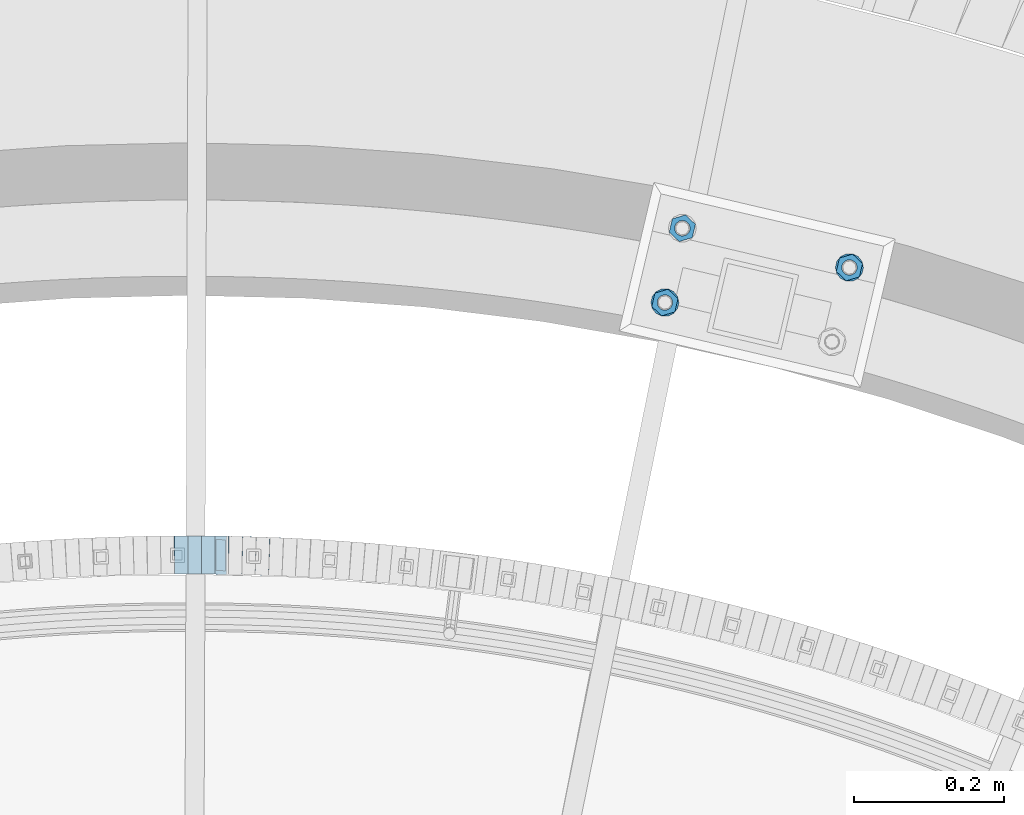
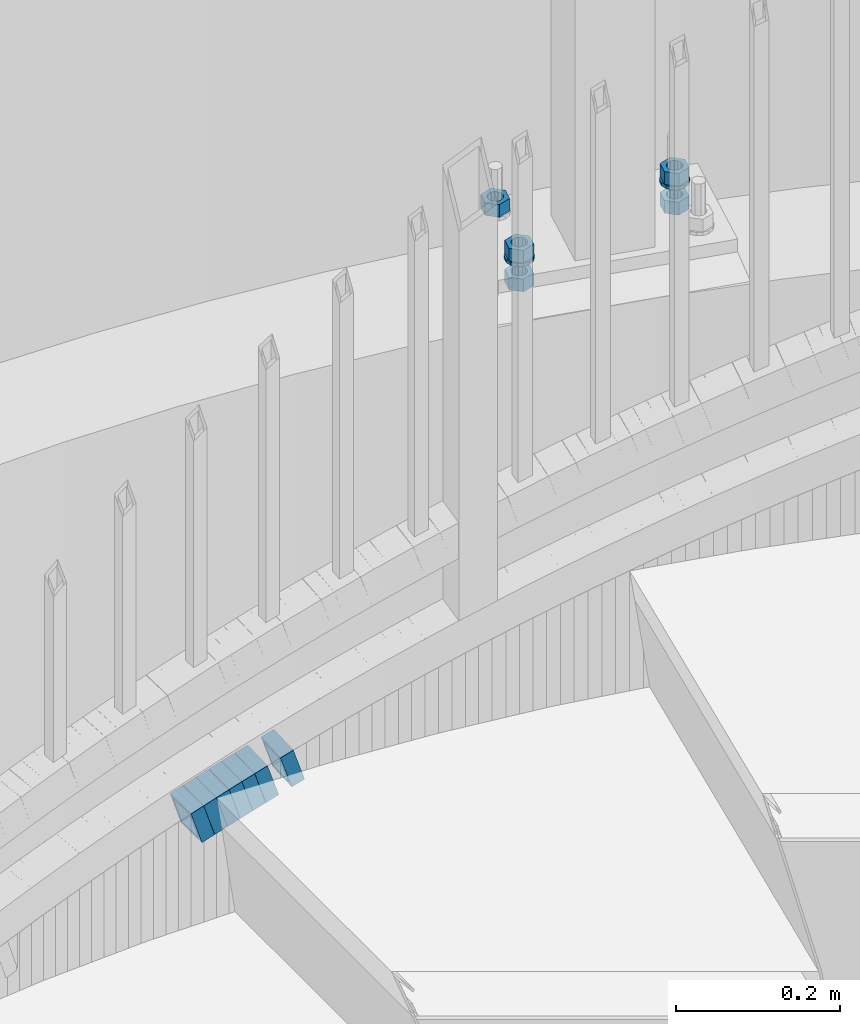
# One storey, part 821 of 975: 14 beams.
"""IFC2X3 building model written with IfcOpenShell, lengths in millimetres."""

from ifc_helpers import new_model, si_unit, frame, origin_with_axes, place, context, subcontext, project, spatial, faceted_brep, material, type_object, element, save


model = new_model("IFC2X3")

# Units and contexts
model_context = context("Model", 3, precision=1e-05, world=origin_with_axes())
body_context = subcontext(model_context, "Body", "Model", "MODEL_VIEW")
ifc_project = project(units=[si_unit("LENGTHUNIT", "METRE", prefix="MILLI"), si_unit("AREAUNIT", "SQUARE_METRE"), si_unit("VOLUMEUNIT", "CUBIC_METRE"), si_unit("MASSUNIT", "GRAM", prefix="KILO"), si_unit("TIMEUNIT", "SECOND"), si_unit("PLANEANGLEUNIT", "RADIAN"), si_unit("SOLIDANGLEUNIT", "STERADIAN"), si_unit("THERMODYNAMICTEMPERATUREUNIT", "DEGREE_CELSIUS"), si_unit("LUMINOUSINTENSITYUNIT", "LUMEN")], contexts=[model_context])

# Site, building, storey
site_placement = place(None, origin_with_axes())
site = spatial("IfcSite", under=ifc_project, at=site_placement, CompositionType="ELEMENT")
building_placement = place(site_placement, origin_with_axes())
building = spatial("IfcBuilding", under=site, at=building_placement, Name="Undefined", CompositionType="ELEMENT")
storey_placement = place(building_placement, origin_with_axes())
storey = spatial("IfcBuildingStorey", under=building, at=storey_placement, Name="Undefined", CompositionType="ELEMENT", Elevation=0.0)

# Beams
ifc_material_1 = material()
beam_type_1 = type_object("IfcBeamType", Name="HSS2X2X.188_TUBES", PredefinedType="NOTDEFINED")
beam_1_placement = place(storey_placement, frame((34814.5687142404, 6273.07633758359, 1065.63622706444), z_axis=(-0.0223407912578623, -0.999750413376245, -8.07874585007085e-11), x_axis=(-0.951092204255929, 0.0212534570057345, -0.308175128082886)))
element("IfcBeam", 1, at=beam_1_placement, inside=storey, type_object=beam_type_1, material=ifc_material_1, Name="WALL", ObjectType="HSS2X2X.188_TUBES", context=body_context, shape_type="Brep", body=[
    faceted_brep([(0.0, 20.6374999999753, -20.6375000000298), (0.0, -20.6375000000153, -20.6375000000153), (18.8225928075335, -20.6374999999935, -20.6375000000298), (18.8225928075699, 20.6374999999898, -20.6374999999825), (0.0, -20.6374999999825, 20.6375000000335), (18.8225928075772, -20.637500000008, 20.6375000000226), (0.0, 20.6375000000116, 20.6375000000189), (18.8225928076135, 20.6374999999753, 20.6375000000698), (0.0, 25.3999999999724, -25.4000000000342), (0.0, 25.400000000016, 25.4000000000196), (18.8225928076281, 25.3999999999705, 25.4000000000815), (18.8225928075663, 25.3999999999905, -25.3999999999796), (0.0, -25.399999999976, 25.4000000000378), (18.8225928075808, -25.4000000000087, 25.4000000000233), (0.0, -25.400000000016, -25.4000000000196), (18.8225928075226, -25.3999999999905, -25.4000000000378)], [[[0, 1, 2, 3]], [[1, 4, 5, 2]], [[4, 6, 7, 5]], [[6, 0, 3, 7]], [[8, 9, 10, 11]], [[9, 12, 13, 10]], [[12, 14, 15, 13]], [[14, 8, 11, 15]], [[13, 15, 11, 10], [5, 7, 3, 2]], [[14, 12, 9, 8], [6, 4, 1, 0]]]),
])
beam_2_placement = place(storey_placement, frame((34850.5475291394, 6271.88113774183, 1077.13551160426), z_axis=(-0.0335007382158656, -0.999438692736574, -7.27229689800879e-11), x_axis=(-0.950823807192712, 0.0318711890064615, -0.308088161062496)))
element("IfcBeam", 2, at=beam_2_placement, inside=storey, type_object=beam_type_1, material=ifc_material_1, Name="WALL", ObjectType="HSS2X2X.188_TUBES", context=body_context, shape_type="Brep", body=[
    faceted_brep([(0.0, 20.6374999999753, -20.6375000000298), (0.0, -20.6375000000153, -20.6375000000153), (18.8332159191086, -20.6374999999916, -20.6375000000153), (18.8332159190923, 20.6375000000062, -20.6375000000335), (0.0, -20.6374999999825, 20.6375000000335), (18.8332159191377, -20.6375000000062, 20.6375000000335), (0.0, 20.6375000000116, 20.6375000000189), (18.8332159191141, 20.6374999999916, 20.6375000000116), (0.0, 25.3999999999724, -25.4000000000342), (0.0, 25.400000000016, 25.4000000000196), (18.8332159191159, 25.3999999999905, 25.4000000000124), (18.8332159190886, 25.4000000000069, -25.4000000000415), (0.0, -25.399999999976, 25.4000000000378), (18.8332159191395, -25.4000000000069, 25.4000000000378), (0.0, -25.400000000016, -25.4000000000196), (18.8332159191104, -25.3999999999905, -25.400000000016)], [[[0, 1, 2, 3]], [[1, 4, 5, 2]], [[4, 6, 7, 5]], [[6, 0, 3, 7]], [[8, 9, 10, 11]], [[9, 12, 13, 10]], [[12, 14, 15, 13]], [[14, 8, 11, 15]], [[13, 15, 11, 10], [5, 7, 3, 2]], [[14, 12, 9, 8], [6, 4, 1, 0]]]),
])
beam_3_placement = place(storey_placement, frame((34778.2653805844, 6273.76986666081, 1054.0973225091), z_axis=(-0.011172487285643, -0.999937585816161, -9.16004410100868e-11), x_axis=(-0.952801846813064, 0.0106458309979009, -0.303406174940424)))
element("IfcBeam", 3, at=beam_3_placement, inside=storey, type_object=beam_type_1, material=ifc_material_1, Name="WALL", ObjectType="HSS2X2X.188_TUBES", context=body_context, shape_type="Brep", body=[
    faceted_brep([(0.0, 20.6374999999753, -20.6375000000298), (0.0, -20.6375000000153, -20.6375000000153), (18.7853666454903, -20.6375000000535, -20.6375000000326), (18.785366645363, 20.6374999999862, -20.6375000000044), (0.0, -20.6374999999825, 20.6375000000335), (18.785366645352, -20.6375000000007, 20.6374999999989), (0.0, 20.6375000000116, 20.6375000000189), (18.7853666453102, 20.6375000000025, 20.6374999999753), (0.0, 25.3999999999724, -25.4000000000342), (0.0, 25.400000000016, 25.4000000000196), (18.7853666452065, 25.4000000000451, 25.4000000000351), (18.7853666453739, 25.3999999999833, -25.400000000006), (0.0, -25.399999999976, 25.4000000000378), (18.7853666497213, -25.399999993424, 25.3999999995158), (0.0, -25.400000000016, -25.4000000000196), (18.7853666455194, -25.4000000000633, -25.4000000000406)], [[[0, 1, 2, 3]], [[1, 4, 5, 2]], [[4, 6, 7, 5]], [[6, 0, 3, 7]], [[8, 9, 10, 11]], [[9, 12, 13, 10]], [[12, 14, 15, 13]], [[14, 8, 11, 15]], [[13, 15, 11, 10], [5, 7, 3, 2]], [[14, 12, 9, 8], [6, 4, 1, 0]]]),
])
beam_4_placement = place(storey_placement, frame((34760.2049803266, 6274.05755294013, 1048.43680002986), z_axis=(0.0, -1.0, 0.0), x_axis=(-0.95130708588474, 0.0, -0.308244753962634)))
element("IfcBeam", 4, at=beam_4_placement, inside=storey, type_object=beam_type_1, material=ifc_material_1, Name="WALL", ObjectType="HSS2X2X.188_TUBES", context=body_context, shape_type="Brep", body=[
    faceted_brep([(0.0, 20.6374999999753, -20.6375000000298), (0.0, -20.6375000000153, -20.6375000000153), (18.8225928075335, -20.6374999999935, -20.6375000000298), (18.8225928075699, 20.6374999999898, -20.6374999999825), (0.0, -20.6374999999825, 20.6375000000335), (18.8225928075772, -20.637500000008, 20.6375000000226), (0.0, 20.6375000000116, 20.6375000000189), (18.8225928076135, 20.6374999999753, 20.6375000000698), (0.0, 25.3999999999724, -25.4000000000342), (0.0, 25.400000000016, 25.4000000000196), (18.8225928076281, 25.3999999999705, 25.4000000000815), (18.8225928075663, 25.3999999999905, -25.3999999999796), (0.0, -25.399999999976, 25.4000000000378), (18.8225928075808, -25.4000000000087, 25.4000000000233), (0.0, -25.400000000016, -25.4000000000196), (18.8225928075226, -25.3999999999905, -25.4000000000378)], [[[0, 1, 2, 3]], [[1, 4, 5, 2]], [[4, 6, 7, 5]], [[6, 0, 3, 7]], [[8, 9, 10, 11]], [[9, 12, 13, 10]], [[12, 14, 15, 13]], [[14, 8, 11, 15]], [[13, 15, 11, 10], [5, 7, 3, 2]], [[14, 12, 9, 8], [6, 4, 1, 0]]]),
])
beam_5_placement = place(storey_placement, frame((34796.2249142481, 6273.57079467437, 1059.78497127306), z_axis=(-0.0111104251425932, -0.999938277321731, 8.80345396581106e-11), x_axis=(-0.953288744989842, 0.0105920969998864, -0.301874768996744)))
element("IfcBeam", 5, at=beam_5_placement, inside=storey, type_object=beam_type_1, material=ifc_material_1, Name="WALL", ObjectType="HSS2X2X.188_TUBES", context=body_context, shape_type="Brep", body=[
    faceted_brep([(0.0, 20.6374999999753, -20.6375000000298), (0.0, -20.6375000000153, -20.6375000000153), (18.8814724002259, -20.6375000000171, -20.6374999999753), (18.8814724002277, 20.6374999999916, -20.6374999999716), (0.0, -20.6374999999825, 20.6375000000335), (18.8814724002368, -20.6375000000062, 20.6375000000298), (0.0, 20.6375000000116, 20.6375000000189), (18.8814724002386, 20.6375000000025, 20.6375000000262), (0.0, 25.3999999999724, -25.4000000000342), (0.0, 25.400000000016, 25.4000000000196), (18.8814724002386, 25.4000000000051, 25.4000000000269), (18.8814724002277, 25.3999999999905, -25.399999999976), (0.0, -25.399999999976, 25.4000000000378), (18.8814724002368, -25.4000000000051, 25.4000000000269), (0.0, -25.400000000016, -25.4000000000196), (18.8814724002259, -25.4000000000196, -25.399999999976)], [[[0, 1, 2, 3]], [[1, 4, 5, 2]], [[4, 6, 7, 5]], [[6, 0, 3, 7]], [[8, 9, 10, 11]], [[9, 12, 13, 10]], [[12, 14, 15, 13]], [[14, 8, 11, 15]], [[13, 15, 11, 10], [5, 7, 3, 2]], [[14, 12, 9, 8], [6, 4, 1, 0]]]),
])
beam_6_placement = place(storey_placement, frame((34742.3049803266, 6274.05755294012, 1042.63680002987), z_axis=(0.0, -1.0, 0.0), x_axis=(-0.95130708588474, 0.0, -0.308244753962634)))
element("IfcBeam", 6, at=beam_6_placement, inside=storey, type_object=beam_type_1, material=ifc_material_1, Name="WALL", ObjectType="HSS2X2X.188_TUBES", context=body_context, shape_type="Brep", body=[
    faceted_brep([(0.0, 20.6374999999753, -20.6375000000298), (0.0, -20.6375000000153, -20.6375000000153), (18.8225928075335, -20.6374999999935, -20.6375000000298), (18.8225928075699, 20.6374999999898, -20.6374999999825), (0.0, -20.6374999999825, 20.6375000000335), (18.8225928075772, -20.637500000008, 20.6375000000226), (0.0, 20.6375000000116, 20.6375000000189), (18.8225928076135, 20.6374999999753, 20.6375000000698), (0.0, 25.3999999999724, -25.4000000000342), (0.0, 25.400000000016, 25.4000000000196), (18.8225928076281, 25.3999999999705, 25.4000000000815), (18.8225928075663, 25.3999999999905, -25.3999999999796), (0.0, -25.399999999976, 25.4000000000378), (18.8225928075808, -25.4000000000087, 25.4000000000233), (0.0, -25.400000000016, -25.4000000000196), (18.8225928075226, -25.3999999999905, -25.4000000000378)], [[[0, 1, 2, 3]], [[1, 4, 5, 2]], [[4, 6, 7, 5]], [[6, 0, 3, 7]], [[8, 9, 10, 11]], [[9, 12, 13, 10]], [[12, 14, 15, 13]], [[14, 8, 11, 15]], [[13, 15, 11, 10], [5, 7, 3, 2]], [[14, 12, 9, 8], [6, 4, 1, 0]]]),
])
beam_7_placement = place(storey_placement, frame((34723.9978182452, 6274.14206857905, 1036.79732250914), z_axis=(0.011172487285643, -0.999937585816161, 9.16004410100868e-11), x_axis=(-0.95280184681306, -0.0106458309979009, -0.303406174940435)))
element("IfcBeam", 7, at=beam_7_placement, inside=storey, type_object=beam_type_1, material=ifc_material_1, Name="WALL", ObjectType="HSS2X2X.188_TUBES", context=body_context, shape_type="Brep", body=[
    faceted_brep([(0.0, 20.6374999999753, -20.6375000000298), (0.0, -20.6375000000153, -20.6375000000153), (18.7853666454903, -20.6375000000535, -20.6375000000326), (18.785366645363, 20.6374999999862, -20.6375000000044), (0.0, -20.6374999999825, 20.6375000000335), (18.785366645352, -20.6375000000007, 20.6374999999989), (0.0, 20.6375000000116, 20.6375000000189), (18.7853666453102, 20.6375000000025, 20.6374999999753), (0.0, 25.3999999999724, -25.4000000000342), (0.0, 25.400000000016, 25.4000000000196), (18.7853666452065, 25.4000000000451, 25.4000000000351), (18.7853666453739, 25.3999999999833, -25.400000000006), (0.0, -25.399999999976, 25.4000000000378), (18.7853666497213, -25.399999993424, 25.3999999995158), (0.0, -25.400000000016, -25.4000000000196), (18.7853666455194, -25.4000000000633, -25.4000000000406)], [[[0, 1, 2, 3]], [[1, 4, 5, 2]], [[4, 6, 7, 5]], [[6, 0, 3, 7]], [[8, 9, 10, 11]], [[9, 12, 13, 10]], [[12, 14, 15, 13]], [[14, 8, 11, 15]], [[13, 15, 11, 10], [5, 7, 3, 2]], [[14, 12, 9, 8], [6, 4, 1, 0]]]),
])
ifc_material_2 = material(Name="STEEL/A36")
beam_type_2 = type_object("IfcBeamType", Name="3/4_WASHER", PredefinedType="NOTDEFINED")
beam_8_placement = place(storey_placement, frame((35615.5839971369, 6657.01756434433, 1433.5125), z_axis=(-0.973539033329667, 0.228520788077446, 0.0), x_axis=(0.0, 0.0, -1.0)))
element("IfcBeam", 8, at=beam_8_placement, inside=storey, type_object=beam_type_2, material=ifc_material_2, Name="WASHER", ObjectType="3/4_WASHER", context=body_context, shape_type="Brep", body=[
    faceted_brep([(0.0, -18.6499996185303, 0.0), (0.0, -16.8030690426876, -8.09193156902904), (4.76250000000073, -16.8030690426876, -8.09193156902904), (4.76250000000073, -18.6499996185303, 0.0), (0.0, -11.6280845668225, -14.5811568497838), (4.76250000000073, -11.6280845668225, -14.5811568497838), (0.0, -4.15001533340001, -18.1824051902857), (4.76250000000073, -4.15001533340001, -18.1824051902857), (0.0, 4.15001533340001, -18.1824051902857), (4.76250000000073, 4.15001533340001, -18.1824051902857), (0.0, 11.6280845668234, -14.5811568497838), (4.76250000000073, 11.6280845668234, -14.5811568497838), (0.0, 16.8030690426876, -8.09193156902904), (4.76250000000073, 16.8030690426876, -8.09193156902904), (0.0, 18.6499996185303, 0.0), (4.76250000000073, 18.6499996185303, 0.0), (0.0, 16.8030690426876, 8.09193156902904), (4.76250000000073, 16.8030690426876, 8.09193156902904), (0.0, 11.6280845668225, 14.5811568497838), (4.76250000000073, 11.6280845668225, 14.5811568497838), (0.0, 4.15001533340001, 18.1824051902857), (4.76250000000073, 4.15001533340001, 18.1824051902857), (0.0, -4.15001533340001, 18.1824051902857), (4.76250000000073, -4.15001533340001, 18.1824051902857), (0.0, -11.6280845668234, 14.5811568497838), (4.76250000000073, -11.6280845668234, 14.5811568497838), (0.0, -16.8030690426876, 8.09193156902904), (4.76250000000073, -16.8030690426876, 8.09193156902904), (0.0, 0.0, 10.3199996948242), (0.0, 4.47768005528269, 9.29799844179911), (4.76250000000073, 4.47768005528269, 9.29799844179911), (4.76250000000073, 0.0, 10.3199996948242), (0.0, 8.06850066047446, 6.43441456490817), (4.76250000000073, 8.06850066047446, 6.43441456490817), (0.0, 10.0612557561917, 2.29641597052117), (4.76250000000073, 10.0612557561917, 2.29641597052117), (0.0, 10.0612557561917, -2.29641597052117), (4.76250000000073, 10.0612557561917, -2.29641597052117), (0.0, 8.06850066047446, -6.43441456490814), (4.76250000000073, 8.06850066047446, -6.43441456490814), (0.0, 4.47768005528269, -9.29799844179908), (4.76250000000073, 4.47768005528269, -9.29799844179908), (0.0, 0.0, -10.3199996948242), (4.76250000000073, 0.0, -10.3199996948242), (0.0, -4.47768005528269, -9.29799844179911), (4.76250000000073, -4.47768005528269, -9.29799844179911), (0.0, -8.06850066047446, -6.43441456490817), (4.76250000000073, -8.06850066047446, -6.43441456490817), (0.0, -10.0612557561917, -2.29641597052117), (4.76250000000073, -10.0612557561917, -2.29641597052117), (0.0, -10.0612557561917, 2.29641597052117), (4.76250000000073, -10.0612557561917, 2.29641597052117), (0.0, -8.06850066047446, 6.43441456490814), (4.76250000000073, -8.06850066047446, 6.43441456490814), (0.0, -4.47768005528269, 9.29799844179908), (4.76250000000073, -4.47768005528269, 9.29799844179908)], [[[0, 1, 2, 3]], [[1, 4, 5, 2]], [[4, 6, 7, 5]], [[6, 8, 9, 7]], [[8, 10, 11, 9]], [[10, 12, 13, 11]], [[12, 14, 15, 13]], [[14, 16, 17, 15]], [[16, 18, 19, 17]], [[18, 20, 21, 19]], [[20, 22, 23, 21]], [[22, 24, 25, 23]], [[24, 26, 27, 25]], [[26, 0, 3, 27]], [[28, 29, 30, 31]], [[29, 32, 33, 30]], [[32, 34, 35, 33]], [[34, 36, 37, 35]], [[36, 38, 39, 37]], [[38, 40, 41, 39]], [[40, 42, 43, 41]], [[42, 44, 45, 43]], [[44, 46, 47, 45]], [[46, 48, 49, 47]], [[48, 50, 51, 49]], [[50, 52, 53, 51]], [[52, 54, 55, 53]], [[54, 28, 31, 55]], [[5, 7, 9, 11, 13, 15, 17, 19, 21, 23, 25, 27, 3, 2], [33, 35, 37, 39, 41, 43, 45, 47, 49, 51, 53, 55, 31, 30]], [[26, 24, 22, 20, 18, 16, 14, 12, 10, 8, 6, 4, 1, 0], [54, 52, 50, 48, 46, 44, 42, 40, 38, 36, 34, 32, 29, 28]]]),
])
beam_9_placement = place(storey_placement, frame((35369.8152679914, 6610.34584931771, 1433.5125), z_axis=(0.973539033329667, -0.228520788077446, 0.0), x_axis=(0.0, 0.0, -1.0)))
element("IfcBeam", 9, at=beam_9_placement, inside=storey, type_object=beam_type_2, material=ifc_material_2, Name="WASHER", ObjectType="3/4_WASHER", context=body_context, shape_type="Brep", body=[
    faceted_brep([(0.0, -18.6499996185303, 0.0), (0.0, -16.8030690426876, -8.09193156902904), (4.76250000000073, -16.8030690426876, -8.09193156902904), (4.76250000000073, -18.6499996185303, 0.0), (0.0, -11.6280845668225, -14.5811568497838), (4.76250000000073, -11.6280845668225, -14.5811568497838), (0.0, -4.15001533340001, -18.1824051902857), (4.76250000000073, -4.15001533340001, -18.1824051902857), (0.0, 4.15001533340001, -18.1824051902857), (4.76250000000073, 4.15001533340001, -18.1824051902857), (0.0, 11.6280845668234, -14.5811568497838), (4.76250000000073, 11.6280845668234, -14.5811568497838), (0.0, 16.8030690426876, -8.09193156902904), (4.76250000000073, 16.8030690426876, -8.09193156902904), (0.0, 18.6499996185303, 0.0), (4.76250000000073, 18.6499996185303, 0.0), (0.0, 16.8030690426876, 8.09193156902904), (4.76250000000073, 16.8030690426876, 8.09193156902904), (0.0, 11.6280845668225, 14.5811568497838), (4.76250000000073, 11.6280845668225, 14.5811568497838), (0.0, 4.15001533340001, 18.1824051902857), (4.76250000000073, 4.15001533340001, 18.1824051902857), (0.0, -4.15001533340001, 18.1824051902857), (4.76250000000073, -4.15001533340001, 18.1824051902857), (0.0, -11.6280845668234, 14.5811568497838), (4.76250000000073, -11.6280845668234, 14.5811568497838), (0.0, -16.8030690426876, 8.09193156902904), (4.76250000000073, -16.8030690426876, 8.09193156902904), (0.0, 0.0, 10.3199996948242), (0.0, 4.47768005528269, 9.29799844179911), (4.76250000000073, 4.47768005528269, 9.29799844179911), (4.76250000000073, 0.0, 10.3199996948242), (0.0, 8.06850066047446, 6.43441456490817), (4.76250000000073, 8.06850066047446, 6.43441456490817), (0.0, 10.0612557561917, 2.29641597052117), (4.76250000000073, 10.0612557561917, 2.29641597052117), (0.0, 10.0612557561917, -2.29641597052117), (4.76250000000073, 10.0612557561917, -2.29641597052117), (0.0, 8.06850066047446, -6.43441456490814), (4.76250000000073, 8.06850066047446, -6.43441456490814), (0.0, 4.47768005528269, -9.29799844179908), (4.76250000000073, 4.47768005528269, -9.29799844179908), (0.0, 0.0, -10.3199996948242), (4.76250000000073, 0.0, -10.3199996948242), (0.0, -4.47768005528269, -9.29799844179911), (4.76250000000073, -4.47768005528269, -9.29799844179911), (0.0, -8.06850066047446, -6.43441456490817), (4.76250000000073, -8.06850066047446, -6.43441456490817), (0.0, -10.0612557561917, -2.29641597052117), (4.76250000000073, -10.0612557561917, -2.29641597052117), (0.0, -10.0612557561917, 2.29641597052117), (4.76250000000073, -10.0612557561917, 2.29641597052117), (0.0, -8.06850066047446, 6.43441456490814), (4.76250000000073, -8.06850066047446, 6.43441456490814), (0.0, -4.47768005528269, 9.29799844179908), (4.76250000000073, -4.47768005528269, 9.29799844179908)], [[[0, 1, 2, 3]], [[1, 4, 5, 2]], [[4, 6, 7, 5]], [[6, 8, 9, 7]], [[8, 10, 11, 9]], [[10, 12, 13, 11]], [[12, 14, 15, 13]], [[14, 16, 17, 15]], [[16, 18, 19, 17]], [[18, 20, 21, 19]], [[20, 22, 23, 21]], [[22, 24, 25, 23]], [[24, 26, 27, 25]], [[26, 0, 3, 27]], [[28, 29, 30, 31]], [[29, 32, 33, 30]], [[32, 34, 35, 33]], [[34, 36, 37, 35]], [[36, 38, 39, 37]], [[38, 40, 41, 39]], [[40, 42, 43, 41]], [[42, 44, 45, 43]], [[44, 46, 47, 45]], [[46, 48, 49, 47]], [[48, 50, 51, 49]], [[50, 52, 53, 51]], [[52, 54, 55, 53]], [[54, 28, 31, 55]], [[5, 7, 9, 11, 13, 15, 17, 19, 21, 23, 25, 27, 3, 2], [33, 35, 37, 39, 41, 43, 45, 47, 49, 51, 53, 55, 31, 30]], [[26, 24, 22, 20, 18, 16, 14, 12, 10, 8, 6, 4, 1, 0], [54, 52, 50, 48, 46, 44, 42, 40, 38, 36, 34, 32, 29, 28]]]),
])
beam_type_3 = type_object("IfcBeamType", Name="3/4_HEAVY_HEX_NUT", PredefinedType="NOTDEFINED")
beam_10_placement = place(storey_placement, frame((35615.5839971369, 6657.01756434433, 1452.5625), z_axis=(-0.973539033329667, 0.228520788077446, 0.0), x_axis=(0.0, 0.0, -1.0)))
element("IfcBeam", 10, at=beam_10_placement, inside=storey, type_object=beam_type_3, material=ifc_material_2, Name="NUT", ObjectType="3/4_HEAVY_HEX_NUT", context=body_context, shape_type="Brep", body=[
    faceted_brep([(0.0, -18.2600002288818, 0.0), (0.0, -9.13000011444092, -15.8100004196167), (19.0499999999993, -9.13000011444092, -15.8100004196167), (19.0499999999993, -18.2600002288818, 0.0), (0.0, 9.13000011444092, -15.8100004196167), (19.0499999999993, 9.13000011444092, -15.8100004196167), (0.0, 18.2600002288818, 0.0), (19.0499999999993, 18.2600002288818, 0.0), (0.0, 9.13000011444092, 15.8100004196167), (19.0499999999993, 9.13000011444092, 15.8100004196167), (0.0, -9.13000011444092, 15.8100004196167), (19.0499999999993, -9.13000011444092, 15.8100004196167), (0.0, 0.0, 10.3199996948242), (0.0, 4.47768005528269, 9.29799844179911), (19.0499999999993, 4.47768005528269, 9.29799844179911), (19.0499999999993, 0.0, 10.3199996948242), (0.0, 8.06850066047446, 6.43441456490817), (19.0499999999993, 8.06850066047446, 6.43441456490817), (0.0, 10.0612557561917, 2.29641597052117), (19.0499999999993, 10.0612557561917, 2.29641597052117), (0.0, 10.0612557561917, -2.29641597052117), (19.0499999999993, 10.0612557561917, -2.29641597052117), (0.0, 8.06850066047446, -6.43441456490814), (19.0499999999993, 8.06850066047446, -6.43441456490814), (0.0, 4.47768005528269, -9.29799844179908), (19.0499999999993, 4.47768005528269, -9.29799844179908), (0.0, 0.0, -10.3199996948242), (19.0499999999993, 0.0, -10.3199996948242), (0.0, -4.47768005528269, -9.29799844179911), (19.0499999999993, -4.47768005528269, -9.29799844179911), (0.0, -8.06850066047446, -6.43441456490817), (19.0499999999993, -8.06850066047446, -6.43441456490817), (0.0, -10.0612557561917, -2.29641597052117), (19.0499999999993, -10.0612557561917, -2.29641597052117), (0.0, -10.0612557561917, 2.29641597052117), (19.0499999999993, -10.0612557561917, 2.29641597052117), (0.0, -8.06850066047446, 6.43441456490814), (19.0499999999993, -8.06850066047446, 6.43441456490814), (0.0, -4.47768005528269, 9.29799844179908), (19.0499999999993, -4.47768005528269, 9.29799844179908)], [[[0, 1, 2, 3]], [[1, 4, 5, 2]], [[4, 6, 7, 5]], [[6, 8, 9, 7]], [[8, 10, 11, 9]], [[10, 0, 3, 11]], [[12, 13, 14, 15]], [[13, 16, 17, 14]], [[16, 18, 19, 17]], [[18, 20, 21, 19]], [[20, 22, 23, 21]], [[22, 24, 25, 23]], [[24, 26, 27, 25]], [[26, 28, 29, 27]], [[28, 30, 31, 29]], [[30, 32, 33, 31]], [[32, 34, 35, 33]], [[34, 36, 37, 35]], [[36, 38, 39, 37]], [[38, 12, 15, 39]], [[5, 7, 9, 11, 3, 2], [17, 19, 21, 23, 25, 27, 29, 31, 33, 35, 37, 39, 15, 14]], [[10, 8, 6, 4, 1, 0], [38, 36, 34, 32, 30, 28, 26, 24, 22, 20, 18, 16, 13, 12]]]),
])
beam_11_placement = place(storey_placement, frame((35615.5839971369, 6657.01756434433, 1409.7), z_axis=(-0.973539033329667, 0.228520788077446, 0.0), x_axis=(0.0, 0.0, -1.0)))
element("IfcBeam", 11, at=beam_11_placement, inside=storey, type_object=beam_type_3, material=ifc_material_2, Name="NUT", ObjectType="3/4_HEAVY_HEX_NUT", context=body_context, shape_type="Brep", body=[
    faceted_brep([(0.0, -18.2600002288818, 0.0), (0.0, -9.13000011444092, -15.8100004196167), (19.0499999999993, -9.13000011444092, -15.8100004196167), (19.0499999999993, -18.2600002288818, 0.0), (0.0, 9.13000011444092, -15.8100004196167), (19.0499999999993, 9.13000011444092, -15.8100004196167), (0.0, 18.2600002288818, 0.0), (19.0499999999993, 18.2600002288818, 0.0), (0.0, 9.13000011444092, 15.8100004196167), (19.0499999999993, 9.13000011444092, 15.8100004196167), (0.0, -9.13000011444092, 15.8100004196167), (19.0499999999993, -9.13000011444092, 15.8100004196167), (0.0, 0.0, 10.3199996948242), (0.0, 4.47768005528269, 9.29799844179911), (19.0499999999993, 4.47768005528269, 9.29799844179911), (19.0499999999993, 0.0, 10.3199996948242), (0.0, 8.06850066047446, 6.43441456490817), (19.0499999999993, 8.06850066047446, 6.43441456490817), (0.0, 10.0612557561917, 2.29641597052117), (19.0499999999993, 10.0612557561917, 2.29641597052117), (0.0, 10.0612557561917, -2.29641597052117), (19.0499999999993, 10.0612557561917, -2.29641597052117), (0.0, 8.06850066047446, -6.43441456490814), (19.0499999999993, 8.06850066047446, -6.43441456490814), (0.0, 4.47768005528269, -9.29799844179908), (19.0499999999993, 4.47768005528269, -9.29799844179908), (0.0, 0.0, -10.3199996948242), (19.0499999999993, 0.0, -10.3199996948242), (0.0, -4.47768005528269, -9.29799844179911), (19.0499999999993, -4.47768005528269, -9.29799844179911), (0.0, -8.06850066047446, -6.43441456490817), (19.0499999999993, -8.06850066047446, -6.43441456490817), (0.0, -10.0612557561917, -2.29641597052117), (19.0499999999993, -10.0612557561917, -2.29641597052117), (0.0, -10.0612557561917, 2.29641597052117), (19.0499999999993, -10.0612557561917, 2.29641597052117), (0.0, -8.06850066047446, 6.43441456490814), (19.0499999999993, -8.06850066047446, 6.43441456490814), (0.0, -4.47768005528269, 9.29799844179908), (19.0499999999993, -4.47768005528269, 9.29799844179908)], [[[0, 1, 2, 3]], [[1, 4, 5, 2]], [[4, 6, 7, 5]], [[6, 8, 9, 7]], [[8, 10, 11, 9]], [[10, 0, 3, 11]], [[12, 13, 14, 15]], [[13, 16, 17, 14]], [[16, 18, 19, 17]], [[18, 20, 21, 19]], [[20, 22, 23, 21]], [[22, 24, 25, 23]], [[24, 26, 27, 25]], [[26, 28, 29, 27]], [[28, 30, 31, 29]], [[30, 32, 33, 31]], [[32, 34, 35, 33]], [[34, 36, 37, 35]], [[36, 38, 39, 37]], [[38, 12, 15, 39]], [[5, 7, 9, 11, 3, 2], [17, 19, 21, 23, 25, 27, 29, 31, 33, 35, 37, 39, 15, 14]], [[10, 8, 6, 4, 1, 0], [38, 36, 34, 32, 30, 28, 26, 24, 22, 20, 18, 16, 13, 12]]]),
])
beam_12_placement = place(storey_placement, frame((35369.8152679914, 6610.34584931771, 1452.5625), z_axis=(0.973539033329667, -0.228520788077446, 0.0), x_axis=(0.0, 0.0, -1.0)))
element("IfcBeam", 12, at=beam_12_placement, inside=storey, type_object=beam_type_3, material=ifc_material_2, Name="NUT", ObjectType="3/4_HEAVY_HEX_NUT", context=body_context, shape_type="Brep", body=[
    faceted_brep([(0.0, -18.2600002288818, 0.0), (0.0, -9.13000011444092, -15.8100004196167), (19.0499999999993, -9.13000011444092, -15.8100004196167), (19.0499999999993, -18.2600002288818, 0.0), (0.0, 9.13000011444092, -15.8100004196167), (19.0499999999993, 9.13000011444092, -15.8100004196167), (0.0, 18.2600002288818, 0.0), (19.0499999999993, 18.2600002288818, 0.0), (0.0, 9.13000011444092, 15.8100004196167), (19.0499999999993, 9.13000011444092, 15.8100004196167), (0.0, -9.13000011444092, 15.8100004196167), (19.0499999999993, -9.13000011444092, 15.8100004196167), (0.0, 0.0, 10.3199996948242), (0.0, 4.47768005528269, 9.29799844179911), (19.0499999999993, 4.47768005528269, 9.29799844179911), (19.0499999999993, 0.0, 10.3199996948242), (0.0, 8.06850066047446, 6.43441456490817), (19.0499999999993, 8.06850066047446, 6.43441456490817), (0.0, 10.0612557561917, 2.29641597052117), (19.0499999999993, 10.0612557561917, 2.29641597052117), (0.0, 10.0612557561917, -2.29641597052117), (19.0499999999993, 10.0612557561917, -2.29641597052117), (0.0, 8.06850066047446, -6.43441456490814), (19.0499999999993, 8.06850066047446, -6.43441456490814), (0.0, 4.47768005528269, -9.29799844179908), (19.0499999999993, 4.47768005528269, -9.29799844179908), (0.0, 0.0, -10.3199996948242), (19.0499999999993, 0.0, -10.3199996948242), (0.0, -4.47768005528269, -9.29799844179911), (19.0499999999993, -4.47768005528269, -9.29799844179911), (0.0, -8.06850066047446, -6.43441456490817), (19.0499999999993, -8.06850066047446, -6.43441456490817), (0.0, -10.0612557561917, -2.29641597052117), (19.0499999999993, -10.0612557561917, -2.29641597052117), (0.0, -10.0612557561917, 2.29641597052117), (19.0499999999993, -10.0612557561917, 2.29641597052117), (0.0, -8.06850066047446, 6.43441456490814), (19.0499999999993, -8.06850066047446, 6.43441456490814), (0.0, -4.47768005528269, 9.29799844179908), (19.0499999999993, -4.47768005528269, 9.29799844179908)], [[[0, 1, 2, 3]], [[1, 4, 5, 2]], [[4, 6, 7, 5]], [[6, 8, 9, 7]], [[8, 10, 11, 9]], [[10, 0, 3, 11]], [[12, 13, 14, 15]], [[13, 16, 17, 14]], [[16, 18, 19, 17]], [[18, 20, 21, 19]], [[20, 22, 23, 21]], [[22, 24, 25, 23]], [[24, 26, 27, 25]], [[26, 28, 29, 27]], [[28, 30, 31, 29]], [[30, 32, 33, 31]], [[32, 34, 35, 33]], [[34, 36, 37, 35]], [[36, 38, 39, 37]], [[38, 12, 15, 39]], [[5, 7, 9, 11, 3, 2], [17, 19, 21, 23, 25, 27, 29, 31, 33, 35, 37, 39, 15, 14]], [[10, 8, 6, 4, 1, 0], [38, 36, 34, 32, 30, 28, 26, 24, 22, 20, 18, 16, 13, 12]]]),
])
beam_13_placement = place(storey_placement, frame((35369.8152679914, 6610.34584931771, 1409.7), z_axis=(0.973539033329667, -0.228520788077446, 0.0), x_axis=(0.0, 0.0, -1.0)))
element("IfcBeam", 13, at=beam_13_placement, inside=storey, type_object=beam_type_3, material=ifc_material_2, Name="NUT", ObjectType="3/4_HEAVY_HEX_NUT", context=body_context, shape_type="Brep", body=[
    faceted_brep([(0.0, -18.2600002288818, 0.0), (0.0, -9.13000011444092, -15.8100004196167), (19.0499999999993, -9.13000011444092, -15.8100004196167), (19.0499999999993, -18.2600002288818, 0.0), (0.0, 9.13000011444092, -15.8100004196167), (19.0499999999993, 9.13000011444092, -15.8100004196167), (0.0, 18.2600002288818, 0.0), (19.0499999999993, 18.2600002288818, 0.0), (0.0, 9.13000011444092, 15.8100004196167), (19.0499999999993, 9.13000011444092, 15.8100004196167), (0.0, -9.13000011444092, 15.8100004196167), (19.0499999999993, -9.13000011444092, 15.8100004196167), (0.0, 0.0, 10.3199996948242), (0.0, 4.47768005528269, 9.29799844179911), (19.0499999999993, 4.47768005528269, 9.29799844179911), (19.0499999999993, 0.0, 10.3199996948242), (0.0, 8.06850066047446, 6.43441456490817), (19.0499999999993, 8.06850066047446, 6.43441456490817), (0.0, 10.0612557561917, 2.29641597052117), (19.0499999999993, 10.0612557561917, 2.29641597052117), (0.0, 10.0612557561917, -2.29641597052117), (19.0499999999993, 10.0612557561917, -2.29641597052117), (0.0, 8.06850066047446, -6.43441456490814), (19.0499999999993, 8.06850066047446, -6.43441456490814), (0.0, 4.47768005528269, -9.29799844179908), (19.0499999999993, 4.47768005528269, -9.29799844179908), (0.0, 0.0, -10.3199996948242), (19.0499999999993, 0.0, -10.3199996948242), (0.0, -4.47768005528269, -9.29799844179911), (19.0499999999993, -4.47768005528269, -9.29799844179911), (0.0, -8.06850066047446, -6.43441456490817), (19.0499999999993, -8.06850066047446, -6.43441456490817), (0.0, -10.0612557561917, -2.29641597052117), (19.0499999999993, -10.0612557561917, -2.29641597052117), (0.0, -10.0612557561917, 2.29641597052117), (19.0499999999993, -10.0612557561917, 2.29641597052117), (0.0, -8.06850066047446, 6.43441456490814), (19.0499999999993, -8.06850066047446, 6.43441456490814), (0.0, -4.47768005528269, 9.29799844179908), (19.0499999999993, -4.47768005528269, 9.29799844179908)], [[[0, 1, 2, 3]], [[1, 4, 5, 2]], [[4, 6, 7, 5]], [[6, 8, 9, 7]], [[8, 10, 11, 9]], [[10, 0, 3, 11]], [[12, 13, 14, 15]], [[13, 16, 17, 14]], [[16, 18, 19, 17]], [[18, 20, 21, 19]], [[20, 22, 23, 21]], [[22, 24, 25, 23]], [[24, 26, 27, 25]], [[26, 28, 29, 27]], [[28, 30, 31, 29]], [[30, 32, 33, 31]], [[32, 34, 35, 33]], [[34, 36, 37, 35]], [[36, 38, 39, 37]], [[38, 12, 15, 39]], [[5, 7, 9, 11, 3, 2], [17, 19, 21, 23, 25, 27, 29, 31, 33, 35, 37, 39, 15, 14]], [[10, 8, 6, 4, 1, 0], [38, 36, 34, 32, 30, 28, 26, 24, 22, 20, 18, 16, 13, 12]]]),
])
beam_14_placement = place(storey_placement, frame((35393.032974118, 6709.25741649908, 1452.5625), z_axis=(-0.973539033329667, 0.228520788077446, 0.0), x_axis=(0.0, 0.0, -1.0)))
element("IfcBeam", 14, at=beam_14_placement, inside=storey, type_object=beam_type_3, material=ifc_material_2, Name="NUT", ObjectType="3/4_HEAVY_HEX_NUT", context=body_context, shape_type="Brep", body=[
    faceted_brep([(0.0, -18.2600002288818, 0.0), (0.0, -9.13000011444092, -15.8100004196167), (19.0499999999993, -9.13000011444092, -15.8100004196167), (19.0499999999993, -18.2600002288818, 0.0), (0.0, 9.13000011444092, -15.8100004196167), (19.0499999999993, 9.13000011444092, -15.8100004196167), (0.0, 18.2600002288818, 0.0), (19.0499999999993, 18.2600002288818, 0.0), (0.0, 9.13000011444092, 15.8100004196167), (19.0499999999993, 9.13000011444092, 15.8100004196167), (0.0, -9.13000011444092, 15.8100004196167), (19.0499999999993, -9.13000011444092, 15.8100004196167), (0.0, 0.0, 10.3199996948242), (0.0, 4.47768005528269, 9.29799844179911), (19.0499999999993, 4.47768005528269, 9.29799844179911), (19.0499999999993, 0.0, 10.3199996948242), (0.0, 8.06850066047446, 6.43441456490817), (19.0499999999993, 8.06850066047446, 6.43441456490817), (0.0, 10.0612557561917, 2.29641597052117), (19.0499999999993, 10.0612557561917, 2.29641597052117), (0.0, 10.0612557561917, -2.29641597052117), (19.0499999999993, 10.0612557561917, -2.29641597052117), (0.0, 8.06850066047446, -6.43441456490814), (19.0499999999993, 8.06850066047446, -6.43441456490814), (0.0, 4.47768005528269, -9.29799844179908), (19.0499999999993, 4.47768005528269, -9.29799844179908), (0.0, 0.0, -10.3199996948242), (19.0499999999993, 0.0, -10.3199996948242), (0.0, -4.47768005528269, -9.29799844179911), (19.0499999999993, -4.47768005528269, -9.29799844179911), (0.0, -8.06850066047446, -6.43441456490817), (19.0499999999993, -8.06850066047446, -6.43441456490817), (0.0, -10.0612557561917, -2.29641597052117), (19.0499999999993, -10.0612557561917, -2.29641597052117), (0.0, -10.0612557561917, 2.29641597052117), (19.0499999999993, -10.0612557561917, 2.29641597052117), (0.0, -8.06850066047446, 6.43441456490814), (19.0499999999993, -8.06850066047446, 6.43441456490814), (0.0, -4.47768005528269, 9.29799844179908), (19.0499999999993, -4.47768005528269, 9.29799844179908)], [[[0, 1, 2, 3]], [[1, 4, 5, 2]], [[4, 6, 7, 5]], [[6, 8, 9, 7]], [[8, 10, 11, 9]], [[10, 0, 3, 11]], [[12, 13, 14, 15]], [[13, 16, 17, 14]], [[16, 18, 19, 17]], [[18, 20, 21, 19]], [[20, 22, 23, 21]], [[22, 24, 25, 23]], [[24, 26, 27, 25]], [[26, 28, 29, 27]], [[28, 30, 31, 29]], [[30, 32, 33, 31]], [[32, 34, 35, 33]], [[34, 36, 37, 35]], [[36, 38, 39, 37]], [[38, 12, 15, 39]], [[5, 7, 9, 11, 3, 2], [17, 19, 21, 23, 25, 27, 29, 31, 33, 35, 37, 39, 15, 14]], [[10, 8, 6, 4, 1, 0], [38, 36, 34, 32, 30, 28, 26, 24, 22, 20, 18, 16, 13, 12]]]),
])

save(model, "model.ifc")
